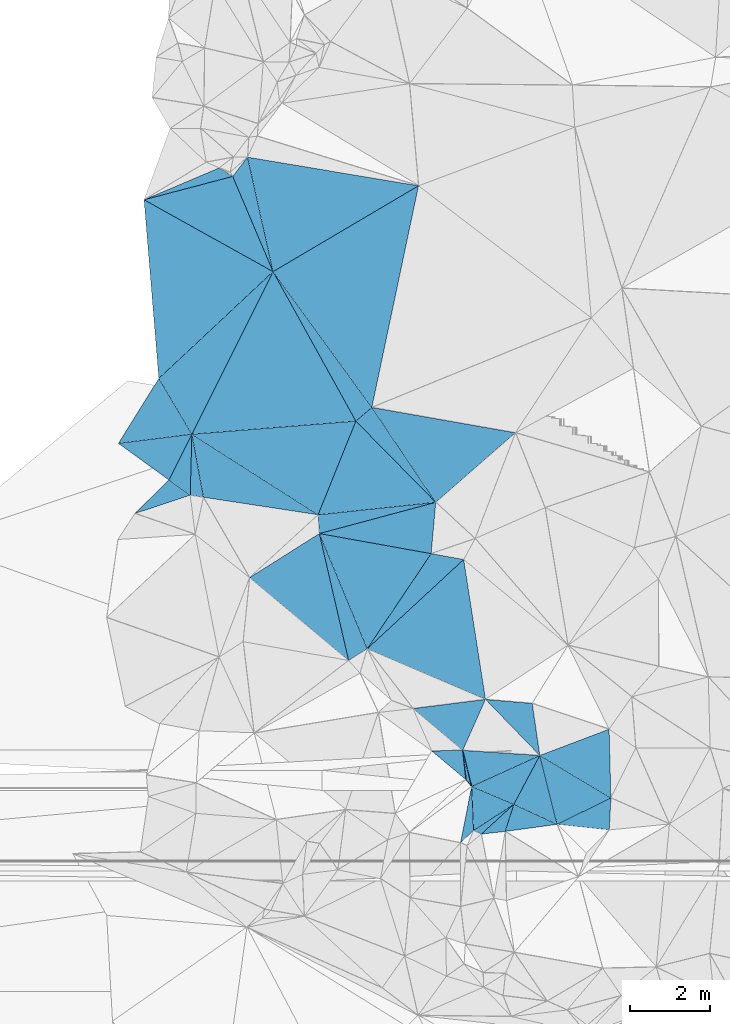
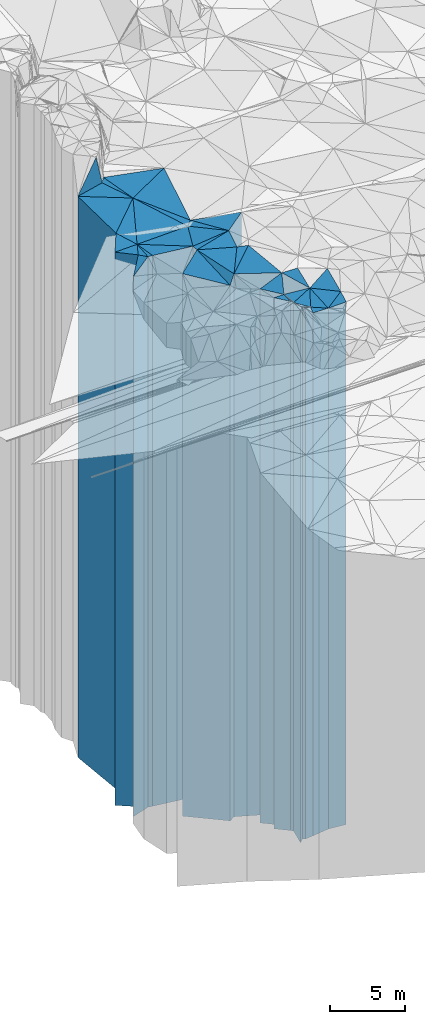
# One storey, part 216 of 275: 41 plates.
"""IFC2X3 building model written with IfcOpenShell, lengths in millimetres."""

from ifc_helpers import new_model, si_unit, frame, origin_with_axes, place, context, subcontext, project, spatial, faceted_brep, material, type_object, element, save


model = new_model("IFC2X3")

# Units and contexts
model_context = context("Model", 3, precision=1e-05, world=origin_with_axes())
body_context = subcontext(model_context, "Body", "Model", "MODEL_VIEW")
ifc_project = project(units=[si_unit("LENGTHUNIT", "METRE", prefix="MILLI"), si_unit("AREAUNIT", "SQUARE_METRE"), si_unit("VOLUMEUNIT", "CUBIC_METRE"), si_unit("MASSUNIT", "GRAM", prefix="KILO"), si_unit("TIMEUNIT", "SECOND"), si_unit("PLANEANGLEUNIT", "RADIAN"), si_unit("SOLIDANGLEUNIT", "STERADIAN"), si_unit("THERMODYNAMICTEMPERATUREUNIT", "DEGREE_CELSIUS"), si_unit("LUMINOUSINTENSITYUNIT", "LUMEN")], contexts=[model_context])

# Site, building, storey
site_placement = place(None, origin_with_axes())
site = spatial("IfcSite", under=ifc_project, at=site_placement, CompositionType="ELEMENT")
building_placement = place(site_placement, origin_with_axes())
building = spatial("IfcBuilding", under=site, at=building_placement, Name="Undefined", CompositionType="ELEMENT")
storey_placement = place(building_placement, origin_with_axes())
storey = spatial("IfcBuildingStorey", under=building, at=storey_placement, Name="Undefined", CompositionType="ELEMENT", Elevation=0.0)

# Plates
ifc_material = material()
plate_type_1 = type_object("IfcPlateType", PredefinedType="NOTDEFINED")
plate_1_placement = place(storey_placement, frame((-129511.155753123, 67950.2158605128, 29044.0), z_axis=(0.544644603012523, -0.838666952019293, 0.0), x_axis=(-0.838666952019288, -0.544644603012531, 0.0)))
element("IfcPlate", 1, at=plate_1_placement, inside=storey, type_object=plate_type_1, material=ifc_material, Name="00", context=body_context, shape_type="Brep", body=[
    faceted_brep([(-1.45519152283669e-11, -21216.0, 0.0), (1082.41418457031, -21866.0, 180.221069335938), (1082.41418457031, 21216.0, 180.221069335938), (-1.45519152283669e-11, 21216.0, 0.0), (1195.19873046876, -21936.0, 4.94765117764473e-10), (1195.19873046876, 21216.0, 4.94765117764473e-10)], [[[0, 1, 2, 3]], [[1, 4, 5, 2]], [[4, 0, 3, 5]], [[5, 3, 2]], [[4, 1, 0]]]),
])
plate_type_2 = type_object("IfcPlateType", PredefinedType="NOTDEFINED")
plate_2_placement = place(storey_placement, frame((-129511.155753123, 67950.2158605128, 28964.0), z_axis=(0.952592104005345, -0.304250363001708, 0.0), x_axis=(-0.304250363001698, -0.952592104005348, 0.0)))
element("IfcPlate", 2, at=plate_2_placement, inside=storey, type_object=plate_type_2, material=ifc_material, Name="00", context=body_context, shape_type="Brep", body=[
    faceted_brep([(0.0, -21296.0, 1.45519152283669e-11), (148.367019653298, -21136.0, 1174.08996582031), (148.367019653298, 21136.0, 1174.08996582031), (-7.27595761418343e-12, 21136.0, 0.0), (708.378417968743, -21306.0, -3.52156348526478e-09), (708.378417968743, 21136.0, -3.52156348526478e-09)], [[[0, 1, 2, 3]], [[1, 4, 5, 2]], [[4, 0, 3, 5]], [[5, 3, 2]], [[4, 1, 0]]]),
])
plate_type_3 = type_object("IfcPlateType", PredefinedType="NOTDEFINED")
plate_3_placement = place(storey_placement, frame((-128437.867652229, 67451.6653089344, 28964.0), z_axis=(-0.96999564992174, -0.243122271980379, 0.0), x_axis=(-0.243122271980382, 0.969995649921739, 0.0)))
element("IfcPlate", 3, at=plate_3_placement, inside=storey, type_object=plate_type_3, material=ifc_material, Name="00", context=body_context, shape_type="Brep", body=[
    faceted_brep([(2.91038304567337e-11, -21136.0, 1.45519152283669e-11), (744.532104492217, -21296.0, 919.876037597671), (744.532104492217, 21136.0, 919.876037597671), (-7.27595761418343e-12, 21136.0, 0.0), (1765.6727294922, -21886.0, 5.32600097358227e-09), (1765.6727294922, 21136.0, 5.32600097358227e-09)], [[[0, 1, 2, 3]], [[1, 4, 5, 2]], [[4, 0, 3, 5]], [[5, 3, 2]], [[4, 1, 0]]]),
])
plate_type_4 = type_object("IfcPlateType", PredefinedType="NOTDEFINED")
plate_4_placement = place(storey_placement, frame((-129511.155753123, 67950.2158605128, 29044.0), z_axis=(-0.883417115332704, 0.46858745217648, 0.0), x_axis=(0.468587452176476, 0.883417115332706, 0.0)))
element("IfcPlate", 4, at=plate_4_placement, inside=storey, type_object=plate_type_4, material=ifc_material, Name="00", context=body_context, shape_type="Brep", body=[
    faceted_brep([(-1.45519152283669e-11, -21216.0, 0.0), (-99.6090850830207, -21676.0, 1134.62683105469), (-99.6090850830207, 21216.0, 1134.62683105469), (-1.45519152283669e-11, 21216.0, 0.0), (1374.37255859375, -21806.0, 5.79166226089001e-09), (1374.37255859375, 21216.0, 5.79166226089001e-09)], [[[0, 1, 2, 3]], [[1, 4, 5, 2]], [[4, 0, 3, 5]], [[5, 3, 2]], [[4, 1, 0]]]),
])
plate_type_5 = type_object("IfcPlateType", PredefinedType="NOTDEFINED")
plate_5_placement = place(storey_placement, frame((-130699.97832707, 68561.6902162087, 29274.0), z_axis=(0.768298092673218, 0.640092212727741, 0.0), x_axis=(0.640092212727769, -0.768298092673195, 0.0)))
element("IfcPlate", 5, at=plate_5_placement, inside=storey, type_object=plate_type_5, material=ifc_material, Name="00", context=body_context, shape_type="Brep", body=[
    faceted_brep([(0.0, -21496.0, 1.45519152283669e-11), (-612.628112792998, -21646.0, 403.840057373054), (-612.628112792998, 21446.0, 403.840057373054), (-1.45519152283669e-11, 21446.0, 0.0), (218.403289794922, -21446.0, -6.03904481977224e-10), (218.403289794922, 21446.0, -6.03904481977224e-10)], [[[0, 1, 2, 3]], [[1, 4, 5, 2]], [[4, 0, 3, 5]], [[5, 3, 2]], [[4, 1, 0]]]),
])
plate_type_6 = type_object("IfcPlateType", PredefinedType="NOTDEFINED")
plate_6_placement = place(storey_placement, frame((-130699.97832707, 68561.6902162087, 29299.0), z_axis=(-0.993756023424393, -0.111574934047654, 0.0), x_axis=(-0.111574934047653, 0.993756023424393, 0.0)))
element("IfcPlate", 6, at=plate_6_placement, inside=storey, type_object=plate_type_6, material=ifc_material, Name="00", context=body_context, shape_type="Brep", body=[
    faceted_brep([(1.45519152283669e-11, -21471.0, 2.91038304567337e-11), (807.078674316421, -21631.0, 767.283508300825), (807.078674316421, 21471.0, 767.283508300825), (1.45519152283669e-11, 21471.0, 2.91038304567337e-11), (733.757446289077, -21621.0, -7.13043846189976e-10), (733.757446289077, 21471.0, -7.13043846189976e-10)], [[[0, 1, 2, 3]], [[1, 4, 5, 2]], [[4, 0, 3, 5]], [[5, 3, 2]], [[4, 1, 0]]]),
])
plate_type_7 = type_object("IfcPlateType", PredefinedType="NOTDEFINED")
plate_7_placement = place(storey_placement, frame((-130781.847266437, 69290.866104981, 29274.0), z_axis=(0.970795076250484, 0.239910233061905, 0.0), x_axis=(0.239910233061899, -0.970795076250485, 0.0)))
element("IfcPlate", 7, at=plate_7_placement, inside=storey, type_object=plate_type_7, material=ifc_material, Name="00", context=body_context, shape_type="Brep", body=[
    faceted_brep([(0.0, -21646.0, 1.45519152283669e-11), (582.168762207031, -21576.0, 1828.4364013672), (582.168762207031, 21446.0, 1828.4364013672), (-1.45519152283669e-11, 21446.0, 0.0), (923.958862304688, -21446.0, 1.28056854009628e-09), (923.958862304688, 21446.0, 1.28056854009628e-09)], [[[0, 1, 2, 3]], [[1, 4, 5, 2]], [[4, 0, 3, 5]], [[5, 3, 2]], [[4, 1, 0]]]),
])
plate_type_8 = type_object("IfcPlateType", PredefinedType="NOTDEFINED")
plate_8_placement = place(storey_placement, frame((-132017.576409019, 70329.8913626978, 29374.0), z_axis=(0.643559802024442, 0.765395833029068, 0.0), x_axis=(0.765395833029066, -0.643559802024444, 0.0)))
element("IfcPlate", 8, at=plate_8_placement, inside=storey, type_object=plate_type_8, material=ifc_material, Name="00", context=body_context, shape_type="Brep", body=[
    faceted_brep([(0.0, -21796.0, -2.18278728425503e-11), (1232.21057128903, -22336.0, 1334.03796386717), (1232.21057128903, 21546.0, 1334.03796386717), (0.0, 21546.0, -2.18278728425503e-11), (1614.49682617185, -21546.0, 8.55652615427971e-09), (1614.49682617185, 21546.0, 8.55652615427971e-09)], [[[0, 1, 2, 3]], [[1, 4, 5, 2]], [[4, 0, 3, 5]], [[5, 3, 2]], [[4, 1, 0]]]),
])
plate_type_9 = type_object("IfcPlateType", PredefinedType="NOTDEFINED")
plate_9_placement = place(storey_placement, frame((-128867.142005361, 69164.3601240556, 28964.0), z_axis=(0.96999564992174, 0.243122271980379, 0.0), x_axis=(0.243122271980384, -0.969995649921739, 0.0)))
element("IfcPlate", 9, at=plate_9_placement, inside=storey, type_object=plate_type_9, material=ifc_material, Name="00", context=body_context, shape_type="Brep", body=[
    faceted_brep([(-1.45519152283669e-11, -21886.0, 0.0), (1453.38378906247, -21626.0, 1458.14111328126), (1453.38378906247, 21136.0, 1458.14111328126), (-7.27595761418343e-12, 21136.0, 0.0), (1765.67272949217, -21136.0, 5.29689714312553e-09), (1765.6727294922, 21136.0, 5.32600097358227e-09)], [[[0, 1, 2, 3]], [[1, 4, 5, 2]], [[4, 0, 3, 5]], [[5, 3, 2]], [[4, 1, 0]]]),
])
plate_type_10 = type_object("IfcPlateType", PredefinedType="NOTDEFINED")
plate_10_placement = place(storey_placement, frame((-133155.994527571, 71816.4996457878, 29859.0), z_axis=(-0.829945610083474, 0.557844319056106, 0.0), x_axis=(0.557844319056105, 0.829945610083474, 0.0)))
element("IfcPlate", 10, at=plate_10_placement, inside=storey, type_object=plate_type_10, material=ifc_material, Name="00", context=body_context, shape_type="Brep", body=[
    faceted_brep([(0.0, -22031.0, 0.0), (1712.94812011717, -22661.0, 2584.70678710938), (1712.94812011717, 22031.0, 2584.70678710938), (0.0, 22031.0, 0.0), (2849.29809570313, -22221.0, 3.00933606922627e-08), (2849.29809570313, 22031.0, 3.00933606922627e-08)], [[[0, 1, 2, 3]], [[1, 4, 5, 2]], [[4, 0, 3, 5]], [[5, 3, 2]], [[4, 1, 0]]]),
])
plate_type_11 = type_object("IfcPlateType", PredefinedType="NOTDEFINED")
plate_11_placement = place(storey_placement, frame((-131452.411561456, 75456.3217674804, 30174.0), z_axis=(0.10512574095853, -0.994458937607743, 0.0), x_axis=(-0.994458937607742, -0.105125740958533, 0.0)))
element("IfcPlate", 11, at=plate_11_placement, inside=storey, type_object=plate_type_11, material=ifc_material, Name="00", context=body_context, shape_type="Brep", body=[
    faceted_brep([(-2.91038304567337e-11, -22426.0, 1.45519152283669e-11), (2958.76879882811, -22346.0, 467.854034423828), (2958.76879882811, 22346.0, 467.854034423828), (-2.91038304567337e-11, 22346.0, 1.45519152283669e-11), (2941.0881347656, -22366.0, -5.58793544769287e-09), (2941.0881347656, 22346.0, -5.58793544769287e-09)], [[[0, 1, 2, 3]], [[1, 4, 5, 2]], [[4, 0, 3, 5]], [[5, 3, 2]], [[4, 1, 0]]]),
])
plate_type_12 = type_object("IfcPlateType", PredefinedType="NOTDEFINED")
plate_12_placement = place(storey_placement, frame((-134345.602101279, 74680.0173811225, 29954.0), z_axis=(0.176646005962772, 0.984274447792586, 0.0), x_axis=(0.984274447792585, -0.176646005962777, 0.0)))
element("IfcPlate", 12, at=plate_12_placement, inside=storey, type_object=plate_type_12, material=ifc_material, Name="00", context=body_context, shape_type="Brep", body=[
    faceted_brep([(0.0, -22566.0, 1.45519152283669e-11), (2710.5625, -22646.0, 1275.16711425781), (2710.5625, 22126.0, 1275.16711425781), (0.0, 22126.0, 1.45519152283669e-11), (2823.47314453125, -22126.0, -8.00355337560177e-09), (2823.47314453125, 22126.0, -8.00355337560177e-09)], [[[0, 1, 2, 3]], [[1, 4, 5, 2]], [[4, 0, 3, 5]], [[5, 3, 2]], [[4, 1, 0]]]),
])
plate_type_13 = type_object("IfcPlateType", PredefinedType="NOTDEFINED")
plate_13_placement = place(storey_placement, frame((-130758.590418801, 74035.5430296028, 29859.0), z_axis=(-0.177495184991706, -0.984121668953976, 0.0), x_axis=(-0.984121668953979, 0.177495184991694, 0.0)))
element("IfcPlate", 13, at=plate_13_placement, inside=storey, type_object=plate_type_13, material=ifc_material, Name="00", context=body_context, shape_type="Brep", body=[
    faceted_brep([(0.0, -22171.0, 0.0), (1965.46777343747, -22031.0, 2609.33642578125), (1965.46777343747, 22031.0, 2609.33642578125), (0.0, 22031.0, 0.0), (820.975036621094, -22221.0, 1.60071067512035e-09), (820.975036621094, 22031.0, 1.60071067512035e-09)], [[[0, 1, 2, 3]], [[1, 4, 5, 2]], [[4, 0, 3, 5]], [[5, 3, 2]], [[4, 1, 0]]]),
])
plate_type_14 = type_object("IfcPlateType", PredefinedType="NOTDEFINED")
plate_14_placement = place(storey_placement, frame((-130215.914413959, 70557.9572644823, 29769.0), z_axis=(-0.988042209599828, -0.154183630937558, 0.0), x_axis=(-0.154183630937555, 0.988042209599829, 0.0)))
element("IfcPlate", 14, at=plate_14_placement, inside=storey, type_object=plate_type_14, material=ifc_material, Name="00", context=body_context, shape_type="Brep", body=[
    faceted_brep([(0.0, -21941.0, 2.91038304567337e-11), (1696.80517578128, -22121.0, 2710.8767089844), (1696.80517578128, 21941.0, 2710.8767089844), (0.0, 21941.0, 2.91038304567337e-11), (3519.67333984376, -22261.0, 2.05036485567689e-08), (3519.67333984376, 21941.0, 2.05036485567689e-08)], [[[0, 1, 2, 3]], [[1, 4, 5, 2]], [[4, 0, 3, 5]], [[5, 3, 2]], [[4, 1, 0]]]),
])
plate_type_15 = type_object("IfcPlateType", PredefinedType="NOTDEFINED")
plate_15_placement = place(storey_placement, frame((-137514.874258297, 77149.2913624284, 30169.0), z_axis=(0.999644031125808, -0.0266797870033586, 0.0), x_axis=(-0.0266797870033648, -0.999644031125808, 0.0)))
element("IfcPlate", 15, at=plate_15_placement, inside=storey, type_object=plate_type_15, material=ifc_material, Name="00", context=body_context, shape_type="Brep", body=[
    faceted_brep([(0.0, -22411.0, 0.0), (1558.97875976563, -22351.0, 330.128936767607), (1558.97875976563, 22341.0, 330.128936767607), (0.0, 22341.0, 0.0), (1516.37731933594, -22341.0, -1.62981450557709e-09), (1516.37731933594, 22341.0, -1.62981450557709e-09)], [[[0, 1, 2, 3]], [[1, 4, 5, 2]], [[4, 0, 3, 5]], [[5, 3, 2]], [[4, 1, 0]]]),
])
plate_type_16 = type_object("IfcPlateType", PredefinedType="NOTDEFINED")
plate_16_placement = place(storey_placement, frame((-137514.874258297, 77149.2913624284, 30169.0), z_axis=(0.894373521160564, -0.447320919080311, 0.0), x_axis=(-0.447320919080307, -0.894373521160566, 0.0)))
element("IfcPlate", 16, at=plate_16_placement, inside=storey, type_object=plate_type_16, material=ifc_material, Name="00", context=body_context, shape_type="Brep", body=[
    faceted_brep([(0.0, -22411.0, 0.0), (1373.82202148437, -22341.0, 641.882507324219), (1373.82202148437, 22341.0, 641.882507324219), (0.0, 22341.0, 0.0), (1271.41650390625, -22441.0, -8.73114913702011e-09), (1271.41650390625, 22341.0, -8.73114913702011e-09)], [[[0, 1, 2, 3]], [[1, 4, 5, 2]], [[4, 0, 3, 5]], [[5, 3, 2]], [[4, 1, 0]]]),
])
plate_type_17 = type_object("IfcPlateType", PredefinedType="NOTDEFINED")
plate_17_placement = place(storey_placement, frame((-137514.874258297, 77149.2913624284, 30204.0), z_axis=(-0.860515744203747, -0.509423845120613, 0.0), x_axis=(-0.509423845120615, 0.860515744203746, 0.0)))
element("IfcPlate", 17, at=plate_17_placement, inside=storey, type_object=plate_type_17, material=ifc_material, Name="00", context=body_context, shape_type="Brep", body=[
    faceted_brep([(0.0, -22376.0, -1.45519152283669e-11), (733.843933105469, -22516.0, 1685.22192382811), (733.843933105469, 22376.0, 1685.22192382811), (0.0, 22376.0, -1.45519152283669e-11), (1611.24169921875, -22726.0, -1.87719706445932e-09), (1611.24169921875, 22376.0, -1.87719706445932e-09)], [[[0, 1, 2, 3]], [[1, 4, 5, 2]], [[4, 0, 3, 5]], [[5, 3, 2]], [[4, 1, 0]]]),
])
plate_type_18 = type_object("IfcPlateType", PredefinedType="NOTDEFINED")
plate_18_placement = place(storey_placement, frame((-135496.783656176, 81190.591935466, 30204.0), z_axis=(0.683028233055611, -0.730391972059476, 0.0), x_axis=(-0.730391972059472, -0.683028233055615, 0.0)))
element("IfcPlate", 18, at=plate_18_placement, inside=storey, type_object=plate_type_18, material=ifc_material, Name="00", context=body_context, shape_type="Brep", body=[
    faceted_brep([(-7.27595761418343e-12, -22976.0, 0.0), (4234.31933593749, -22376.0, 1573.32067871094), (4234.31933593749, 22376.0, 1573.32067871094), (0.0, 22376.0, -1.45519152283669e-11), (3886.81103515623, -22726.0, -1.87719706445932e-08), (3886.81103515623, 22376.0, -1.87719706445932e-08)], [[[0, 1, 2, 3]], [[1, 4, 5, 2]], [[4, 0, 3, 5]], [[5, 3, 2]], [[4, 1, 0]]]),
])
plate_type_19 = type_object("IfcPlateType", PredefinedType="NOTDEFINED")
plate_19_placement = place(storey_placement, frame((-139338.871893476, 76922.2833738925, 30204.0), z_axis=(0.586986652969347, 0.809596608957722, 0.0), x_axis=(0.809596608957719, -0.586986652969352, 0.0)))
element("IfcPlate", 19, at=plate_19_placement, inside=storey, type_object=plate_type_19, material=ifc_material, Name="00", context=body_context, shape_type="Brep", body=[
    faceted_brep([(0.0, -22516.0, 3.63797880709171e-12), (1343.45166015625, -22376.0, 1254.44714355468), (1343.45166015625, 22376.0, 1254.44714355468), (0.0, 22376.0, -1.45519152283669e-11), (1550.48376464844, -22406.0, 7.21411197446287e-09), (1550.48376464844, 22376.0, 7.21411197446287e-09)], [[[0, 1, 2, 3]], [[1, 4, 5, 2]], [[4, 0, 3, 5]], [[5, 3, 2]], [[4, 1, 0]]]),
])
plate_type_20 = type_object("IfcPlateType", PredefinedType="NOTDEFINED")
plate_20_placement = place(storey_placement, frame((-134377.203041995, 75147.1376874097, 30129.0), z_axis=(-0.927486726858566, 0.373856083942985, 0.0), x_axis=(0.373856083942991, 0.927486726858563, 0.0)))
element("IfcPlate", 20, at=plate_20_placement, inside=storey, type_object=plate_type_20, material=ifc_material, Name="00", context=body_context, shape_type="Brep", body=[
    faceted_brep([(0.0, -22411.0, 0.0), (683.933471679717, -22451.0, 3658.66577148438), (683.933471679717, 22301.0, 3658.66577148438), (7.27595761418343e-12, 22301.0, 0.0), (2510.47802734375, -22301.0, 1.26601662486792e-08), (2510.47802734375, 22301.0, 1.26601662486792e-08)], [[[0, 1, 2, 3]], [[1, 4, 5, 2]], [[4, 0, 3, 5]], [[5, 3, 2]], [[4, 1, 0]]]),
])
plate_type_21 = type_object("IfcPlateType", PredefinedType="NOTDEFINED")
plate_21_placement = place(storey_placement, frame((-137226.456067813, 75582.0597434907, 30174.0), z_axis=(0.150896396948921, 0.988549582665348, 0.0), x_axis=(0.988549582665348, -0.15089639694892, 0.0)))
element("IfcPlate", 21, at=plate_21_placement, inside=storey, type_object=plate_type_21, material=ifc_material, Name="00", context=body_context, shape_type="Brep", body=[
    faceted_brep([(-2.91038304567337e-11, -22346.0, 7.27595761418343e-12), (-521.60528564456, -22406.0, 1505.76489257811), (-521.60528564456, 22346.0, 1505.76489257811), (-2.91038304567337e-11, 22346.0, 1.45519152283669e-11), (2882.2561035156, -22366.0, 2.42798705585301e-08), (2882.2561035156, 22346.0, 2.42798705585301e-08)], [[[0, 1, 2, 3]], [[1, 4, 5, 2]], [[4, 0, 3, 5]], [[5, 3, 2]], [[4, 1, 0]]]),
])
plate_type_22 = type_object("IfcPlateType", PredefinedType="NOTDEFINED")
plate_22_placement = place(storey_placement, frame((-133042.013059194, 77814.9584665905, 30099.0), z_axis=(0.829252502913538, 0.558874123941726, 0.0), x_axis=(0.558874123941731, -0.829252502913535, 0.0)))
element("IfcPlate", 22, at=plate_22_placement, inside=storey, type_object=plate_type_22, material=ifc_material, Name="00", context=body_context, shape_type="Brep", body=[
    faceted_brep([(-2.91038304567337e-11, -22471.0, -1.45519152283669e-11), (2517.67358398435, -22271.0, 2608.03002929685), (2517.67358398435, 22271.0, 2608.03002929685), (-2.91038304567337e-11, 22271.0, -1.45519152283669e-11), (2844.29248046872, -22501.0, -8.99308361113071e-09), (2844.29248046872, 22271.0, -8.99308361113071e-09)], [[[0, 1, 2, 3]], [[1, 4, 5, 2]], [[4, 0, 3, 5]], [[5, 3, 2]], [[4, 1, 0]]]),
])
plate_type_23 = type_object("IfcPlateType", PredefinedType="NOTDEFINED")
plate_23_placement = place(storey_placement, frame((-133042.013059194, 77814.9584665905, 30199.0), z_axis=(-0.978518757641569, 0.206157805924489, 0.0), x_axis=(0.206157805924485, 0.97851875764157, 0.0)))
element("IfcPlate", 23, at=plate_23_placement, inside=storey, type_object=plate_type_23, material=ifc_material, Name="00", context=body_context, shape_type="Brep", body=[
    faceted_brep([(0.0, -22371.0, -1.45519152283669e-11), (2797.05053710937, -22981.0, 3097.9521484375), (2797.05053710937, 22371.0, 3097.9521484375), (0.0, 22371.0, 2.91038304567337e-11), (5631.07470703126, -22851.0, -2.47091520577669e-08), (5631.07470703126, 22371.0, -2.47091520577669e-08)], [[[0, 1, 2, 3]], [[1, 4, 5, 2]], [[4, 0, 3, 5]], [[5, 3, 2]], [[4, 1, 0]]]),
])
plate_type_24 = type_object("IfcPlateType", PredefinedType="NOTDEFINED")
plate_24_placement = place(storey_placement, frame((-136499.498721579, 83557.2483316532, 30504.0), z_axis=(0.920766456866242, 0.390114254943326, 0.0), x_axis=(0.390114254943331, -0.92076645686624, 0.0)))
element("IfcPlate", 24, at=plate_24_placement, inside=storey, type_object=plate_type_24, material=ifc_material, Name="00", context=body_context, shape_type="Brep", body=[
    faceted_brep([(-1.45519152283669e-11, -22826.0, 0.0), (-298.212921142593, -22846.0, 525.422729492173), (-298.212921142593, 22676.0, 525.422729492173), (-1.45519152283669e-11, 22676.0, 0.0), (2570.31127929686, -22676.0, 5.79166226089001e-09), (2570.31127929686, 22676.0, 5.79166226089001e-09)], [[[0, 1, 2, 3]], [[1, 4, 5, 2]], [[4, 0, 3, 5]], [[5, 3, 2]], [[4, 1, 0]]]),
])
plate_type_25 = type_object("IfcPlateType", PredefinedType="NOTDEFINED")
plate_25_placement = place(storey_placement, frame((-138702.895086626, 82976.6069117577, 30504.0), z_axis=(0.486650775803546, 0.873596601647355, 0.0), x_axis=(0.873596601647351, -0.486650775803553, 0.0)))
element("IfcPlate", 25, at=plate_25_placement, inside=storey, type_object=plate_type_25, material=ifc_material, Name="00", context=body_context, shape_type="Brep", body=[
    faceted_brep([(0.0, -22846.0, -1.2732925824821e-11), (1642.30993652347, -22826.0, 1579.53088378905), (1642.30993652347, 22676.0, 1579.53088378905), (-1.45519152283669e-11, 22676.0, 0.0), (3670.013671875, -22676.0, -4.06853359891102e-08), (3670.013671875, 22676.0, -4.06853359891102e-08)], [[[0, 1, 2, 3]], [[1, 4, 5, 2]], [[4, 0, 3, 5]], [[5, 3, 2]], [[4, 1, 0]]]),
])
plate_type_26 = type_object("IfcPlateType", PredefinedType="NOTDEFINED")
plate_26_placement = place(storey_placement, frame((-136132.044189616, 84036.8076782821, 30439.0), z_axis=(0.975985630820006, 0.217834910959827, 0.0), x_axis=(0.217834910959824, -0.975985630820006, 0.0)))
element("IfcPlate", 26, at=plate_26_placement, inside=storey, type_object=plate_type_26, material=ifc_material, Name="00", context=body_context, shape_type="Brep", body=[
    faceted_brep([(-1.45519152283669e-11, -22911.0, 0.0), (1620.64428710938, -22611.0, 3993.79663085936), (1620.64428710938, 22611.0, 3993.79663085936), (2.91038304567337e-11, 22611.0, -7.27595761418343e-12), (2916.24755859374, -22741.0, -1.09575921669602e-08), (2916.24755859374, 22611.0, -1.09575921669602e-08)], [[[0, 1, 2, 3]], [[1, 4, 5, 2]], [[4, 0, 3, 5]], [[5, 3, 2]], [[4, 1, 0]]]),
])
plate_type_27 = type_object("IfcPlateType", PredefinedType="NOTDEFINED")
plate_27_placement = place(storey_placement, frame((-136834.157942835, 83770.093828736, 30579.0), z_axis=(0.390837578018542, -0.920459661043655, 0.0), x_axis=(-0.920459661043656, -0.390837578018539, 0.0)))
element("IfcPlate", 27, at=plate_27_placement, inside=storey, type_object=plate_type_27, material=ifc_material, Name="00", context=body_context, shape_type="Brep", body=[
    faceted_brep([(1.45519152283669e-11, -24821.0, -1.45519152283669e-11), (-224.852294921875, -22751.0, 326.713104248032), (-224.852294921875, 22751.0, 326.713104248032), (-3.63797880709171e-12, 22751.0, -2.91038304567337e-11), (2030.22167968751, -22771.0, -1.8364517018199e-08), (2030.22167968751, 22751.0, -1.8364517018199e-08)], [[[0, 1, 2, 3]], [[1, 4, 5, 2]], [[4, 0, 3, 5]], [[5, 3, 2]], [[4, 1, 0]]]),
])
plate_type_28 = type_object("IfcPlateType", PredefinedType="NOTDEFINED")
plate_28_placement = place(storey_placement, frame((-138335.67922947, 78535.7902622829, 30379.0), z_axis=(-0.683028233055611, 0.730391972059476, 0.0), x_axis=(0.730391972059472, 0.683028233055615, 0.0)))
element("IfcPlate", 28, at=plate_28_placement, inside=storey, type_object=plate_type_28, material=ifc_material, Name="00", context=body_context, shape_type="Brep", body=[
    faceted_brep([(0.0, -22551.0, -1.81898940354586e-11), (2764.99169921872, -22971.0, 3494.35571289065), (2764.99169921872, 22551.0, 3494.35571289065), (-1.45519152283669e-11, 22551.0, 2.91038304567337e-11), (3886.81103515624, -22801.0, -1.87719706445932e-08), (3886.81103515624, 22551.0, -1.87719706445932e-08)], [[[0, 1, 2, 3]], [[1, 4, 5, 2]], [[4, 0, 3, 5]], [[5, 3, 2]], [[4, 1, 0]]]),
])
plate_type_29 = type_object("IfcPlateType", PredefinedType="NOTDEFINED")
plate_29_placement = place(storey_placement, frame((-131452.411561456, 75456.3217674804, 30129.0), z_axis=(-0.829252502913538, -0.558874123941726, 0.0), x_axis=(-0.558874123941729, 0.829252502913537, 0.0)))
element("IfcPlate", 29, at=plate_29_placement, inside=storey, type_object=plate_type_29, material=ifc_material, Name="00", context=body_context, shape_type="Brep", body=[
    faceted_brep([(-2.91038304567337e-11, -22471.0, -1.45519152283669e-11), (2784.52368164063, -22301.0, 518.582397460923), (2784.52368164063, 22301.0, 518.582397460923), (7.27595761418343e-12, 22301.0, 0.0), (2844.29248046875, -22441.0, -8.97853169590235e-09), (2844.29248046875, 22301.0, -8.97853169590235e-09)], [[[0, 1, 2, 3]], [[1, 4, 5, 2]], [[4, 0, 3, 5]], [[5, 3, 2]], [[4, 1, 0]]]),
])
plate_type_30 = type_object("IfcPlateType", PredefinedType="NOTDEFINED")
plate_30_placement = place(storey_placement, frame((-137514.874258297, 77149.2913624284, 30129.0), z_axis=(-0.0797897110349555, 0.996811718436816, 0.0), x_axis=(0.996811718436815, 0.0797897110349666, 0.0)))
element("IfcPlate", 30, at=plate_30_placement, inside=storey, type_object=plate_type_30, material=ifc_material, Name="00", context=body_context, shape_type="Brep", body=[
    faceted_brep([(-2.91038304567337e-11, -22451.0, -2.18278728425503e-11), (2334.11059570305, -23051.0, 3867.39282226563), (2334.11059570305, 22301.0, 3867.39282226563), (7.27595761418343e-12, 22301.0, 0.0), (4089.26635742185, -22301.0, -1.41153577715158e-09), (4089.26635742185, 22301.0, -1.41153577715158e-09)], [[[0, 1, 2, 3]], [[1, 4, 5, 2]], [[4, 0, 3, 5]], [[5, 3, 2]], [[4, 1, 0]]]),
])
plate_type_31 = type_object("IfcPlateType", PredefinedType="NOTDEFINED")
plate_31_placement = place(storey_placement, frame((-133438.645553208, 77475.5727499018, 30129.0), z_axis=(-0.650145120649434, 0.759810056590286, 0.0), x_axis=(0.759810056590287, 0.650145120649432, 0.0)))
element("IfcPlate", 31, at=plate_31_placement, inside=storey, type_object=plate_type_31, material=ifc_material, Name="00", context=body_context, shape_type="Brep", body=[
    faceted_brep([(0.0, -22301.0, -1.09139364212751e-11), (851.50756835936, -23051.0, 4160.79736328122), (851.50756835936, 22301.0, 4160.79736328122), (7.27595761418343e-12, 22301.0, 0.0), (522.01531982419, -22441.0, 3.84170562028885e-09), (522.01531982419, 22301.0, 3.84170562028885e-09)], [[[0, 1, 2, 3]], [[1, 4, 5, 2]], [[4, 0, 3, 5]], [[5, 3, 2]], [[4, 1, 0]]]),
])
plate_type_32 = type_object("IfcPlateType", PredefinedType="NOTDEFINED")
plate_32_placement = place(storey_placement, frame((-127099.40146263, 68109.090787069, 29209.0), z_axis=(-0.999661240022081, -0.0260270090005725, 0.0), x_axis=(-0.0260270090005716, 0.999661240022081, 0.0)))
element("IfcPlate", 32, at=plate_32_placement, inside=storey, type_object=plate_type_32, material=ifc_material, Name="00", context=body_context, shape_type="Brep", body=[
    faceted_brep([(-1.09139364212751e-11, -21381.0, -1.45519152283669e-11), (1100.9208984375, -21641.0, 1739.67614746094), (1100.9208984375, 21381.0, 1739.67614746094), (2.91038304567337e-11, 21381.0, 1.63709046319127e-11), (1708.47888183594, -22231.0, -1.17288436740637e-08), (1708.47888183594, 21381.0, -1.17288436740637e-08)], [[[0, 1, 2, 3]], [[1, 4, 5, 2]], [[4, 0, 3, 5]], [[5, 3, 2]], [[4, 1, 0]]]),
])
plate_type_33 = type_object("IfcPlateType", PredefinedType="NOTDEFINED")
plate_33_placement = place(storey_placement, frame((-134345.602101279, 74680.0173811225, 29559.0), z_axis=(0.53375930933421, -0.845636446529516, 0.0), x_axis=(-0.845636446529511, -0.533759309334219, 0.0)))
element("IfcPlate", 33, at=plate_33_placement, inside=storey, type_object=plate_type_33, material=ifc_material, Name="00", context=body_context, shape_type="Brep", body=[
    faceted_brep([(0.0, -22961.0, 1.45519152283669e-11), (1068.34741210936, -21731.0, 3056.65405273435), (1068.34741210936, 21731.0, 3056.65405273435), (0.0, 21731.0, 1.45519152283669e-11), (2052.04785156254, -22301.0, 5.67524693906307e-09), (2052.04785156254, 21731.0, 5.67524693906307e-09)], [[[0, 1, 2, 3]], [[1, 4, 5, 2]], [[4, 0, 3, 5]], [[5, 3, 2]], [[4, 1, 0]]]),
])
plate_type_34 = type_object("IfcPlateType", PredefinedType="NOTDEFINED")
plate_34_placement = place(storey_placement, frame((-133617.518115447, 71524.9589490844, 29559.0), z_axis=(-0.534061234262363, 0.845445798415346, 0.0), x_axis=(0.845445798415332, 0.534061234262386, 0.0)))
element("IfcPlate", 34, at=plate_34_placement, inside=storey, type_object=plate_type_34, material=ifc_material, Name="00", context=body_context, shape_type="Brep", body=[
    faceted_brep([(-1.45519152283669e-11, -21731.0, -2.91038304567337e-11), (1069.43884277335, -22961.0, 3056.27221679685), (1069.43884277335, 21731.0, 3056.27221679685), (0.0, 21731.0, 1.45519152283669e-11), (545.893737792954, -22331.0, -4.10364009439945e-09), (545.893737792954, 21731.0, -4.10364009439945e-09)], [[[0, 1, 2, 3]], [[1, 4, 5, 2]], [[4, 0, 3, 5]], [[5, 3, 2]], [[4, 1, 0]]]),
])
plate_type_35 = type_object("IfcPlateType", PredefinedType="NOTDEFINED")
plate_35_placement = place(storey_placement, frame((-127099.40146263, 68109.090787069, 28964.0), z_axis=(0.440867853743659, -0.897572022478118, 0.0), x_axis=(-0.897572022478116, -0.440867853743664, 0.0)))
element("IfcPlate", 35, at=plate_35_placement, inside=storey, type_object=plate_type_35, material=ifc_material, Name="00", context=body_context, shape_type="Brep", body=[
    faceted_brep([(0.0, -21626.0, -1.45519152283669e-11), (388.275939941421, -21276.0, 694.940124511719), (388.275939941421, 21136.0, 694.940124511719), (-7.27595761418343e-12, 21136.0, 0.0), (1491.20751953125, -21136.0, 6.33008312433958e-09), (1491.20751953125, 21136.0, 6.33008312433958e-09)], [[[0, 1, 2, 3]], [[1, 4, 5, 2]], [[4, 0, 3, 5]], [[5, 3, 2]], [[4, 1, 0]]]),
])
plate_type_36 = type_object("IfcPlateType", PredefinedType="NOTDEFINED")
plate_36_placement = place(storey_placement, frame((-133438.645553208, 77475.5727499018, 30129.0), z_axis=(0.927486726858566, -0.373856083942985, 0.0), x_axis=(-0.373856083942987, -0.927486726858565, 0.0)))
element("IfcPlate", 36, at=plate_36_placement, inside=storey, type_object=plate_type_36, material=ifc_material, Name="00", context=body_context, shape_type="Brep", body=[
    faceted_brep([(0.0, -22301.0, -1.09139364212751e-11), (1130.26281738282, -22471.0, 2597.11499023438), (1130.26281738282, 22301.0, 2597.11499023438), (7.27595761418343e-12, 22301.0, 0.0), (2510.47802734377, -22411.0, 1.26601662486792e-08), (2510.47802734375, 22301.0, 1.26601662486792e-08)], [[[0, 1, 2, 3]], [[1, 4, 5, 2]], [[4, 0, 3, 5]], [[5, 3, 2]], [[4, 1, 0]]]),
])
plate_type_37 = type_object("IfcPlateType", PredefinedType="NOTDEFINED")
plate_37_placement = place(storey_placement, frame((-128867.142005361, 69164.3601240556, 29339.0), z_axis=(-0.989452119290665, -0.144860290042552, 0.0), x_axis=(-0.144860290042552, 0.989452119290665, 0.0)))
element("IfcPlate", 37, at=plate_37_placement, inside=storey, type_object=plate_type_37, material=ifc_material, Name="00", context=body_context, shape_type="Brep", body=[
    faceted_brep([(1.45519152283669e-11, -21511.0, 0.0), (1574.28125, -22371.0, 1132.66882324222), (1574.28125, 21511.0, 1132.66882324222), (0.0, 21511.0, -1.45519152283669e-11), (1307.70788574219, -22411.0, 6.25732354819775e-09), (1307.70788574219, 21511.0, 6.25732354819775e-09)], [[[0, 1, 2, 3]], [[1, 4, 5, 2]], [[4, 0, 3, 5]], [[5, 3, 2]], [[4, 1, 0]]]),
])
plate_type_38 = type_object("IfcPlateType", PredefinedType="NOTDEFINED")
plate_38_placement = place(storey_placement, frame((-130320.784282319, 67209.5393827492, 29044.0), z_axis=(-0.110215382975747, 0.993907726781269, 0.0), x_axis=(0.993907726781268, 0.110215382975751, 0.0)))
element("IfcPlate", 38, at=plate_38_placement, inside=storey, type_object=plate_type_38, material=ifc_material, Name="00", context=body_context, shape_type="Brep", body=[
    faceted_brep([(0.0, -21866.0, 0.0), (886.330017089844, -21216.0, 646.930541992173), (886.330017089844, 21216.0, 646.930541992173), (-1.45519152283669e-11, 21216.0, 0.0), (597.745788574219, -21226.0, 4.23460733145475e-09), (597.745788574219, 21216.0, 4.23460733145475e-09)], [[[0, 1, 2, 3]], [[1, 4, 5, 2]], [[4, 0, 3, 5]], [[5, 3, 2]], [[4, 1, 0]]]),
])
plate_type_39 = type_object("IfcPlateType", PredefinedType="NOTDEFINED")
plate_39_placement = place(storey_placement, frame((-129511.155753123, 67950.2158605128, 29044.0), z_axis=(-0.389533898105914, -0.921012129250431, 0.0), x_axis=(-0.921012129250427, 0.389533898105922, 0.0)))
element("IfcPlate", 39, at=plate_39_placement, inside=storey, type_object=plate_type_39, material=ifc_material, Name="00", context=body_context, shape_type="Brep", body=[
    faceted_brep([(-1.45519152283669e-11, -21216.0, 0.0), (669.627868652373, -21936.0, 989.999206542961), (669.627868652373, 21216.0, 989.999206542961), (-1.45519152283669e-11, 21216.0, 0.0), (1138.99072265625, -21676.0, 5.4424162954092e-09), (1138.99072265625, 21216.0, 5.4424162954092e-09)], [[[0, 1, 2, 3]], [[1, 4, 5, 2]], [[4, 0, 3, 5]], [[5, 3, 2]], [[4, 1, 0]]]),
])
plate_type_40 = type_object("IfcPlateType", PredefinedType="NOTDEFINED")
plate_40_placement = place(storey_placement, frame((-130836.99521211, 66992.2233088755, 29274.0), z_axis=(-0.688444761873538, 0.725288776866765, 0.0), x_axis=(0.725288776866776, 0.688444761873526, 0.0)))
element("IfcPlate", 40, at=plate_40_placement, inside=storey, type_object=plate_type_40, material=ifc_material, Name="00", context=body_context, shape_type="Brep", body=[
    faceted_brep([(0.0, -21766.0, 0.0), (1165.74194335938, -21446.0, 826.04217529294), (1165.74194335938, 21446.0, 826.04217529294), (-1.45519152283669e-11, 21446.0, 0.0), (445.982055664063, -21706.0, 5.82076609134674e-11), (445.982055664063, 21446.0, 5.82076609134674e-11)], [[[0, 1, 2, 3]], [[1, 4, 5, 2]], [[4, 0, 3, 5]], [[5, 3, 2]], [[4, 1, 0]]]),
])
plate_type_41 = type_object("IfcPlateType", PredefinedType="NOTDEFINED")
plate_41_placement = place(storey_placement, frame((-137555.330880387, 75633.4538837622, 29749.0), z_axis=(-0.582640303031042, -0.812730138043309, 0.0), x_axis=(-0.812730138043304, 0.582640303031049, 0.0)))
element("IfcPlate", 41, at=plate_41_placement, inside=storey, type_object=plate_type_41, material=ifc_material, Name="00", context=body_context, shape_type="Brep", body=[
    faceted_brep([(1.63709046319127e-11, -22761.0, -2.91038304567337e-11), (851.692321777344, -21921.0, 1169.53845214842), (851.692321777344, 21921.0, 1169.53845214842), (2.91038304567337e-11, 21921.0, -1.45519152283669e-11), (650.0, -22861.0, 1.43336364999413e-09), (650.0, 21921.0, 1.43336364999413e-09)], [[[0, 1, 2, 3]], [[1, 4, 5, 2]], [[4, 0, 3, 5]], [[5, 3, 2]], [[4, 1, 0]]]),
])

save(model, "model.ifc")
